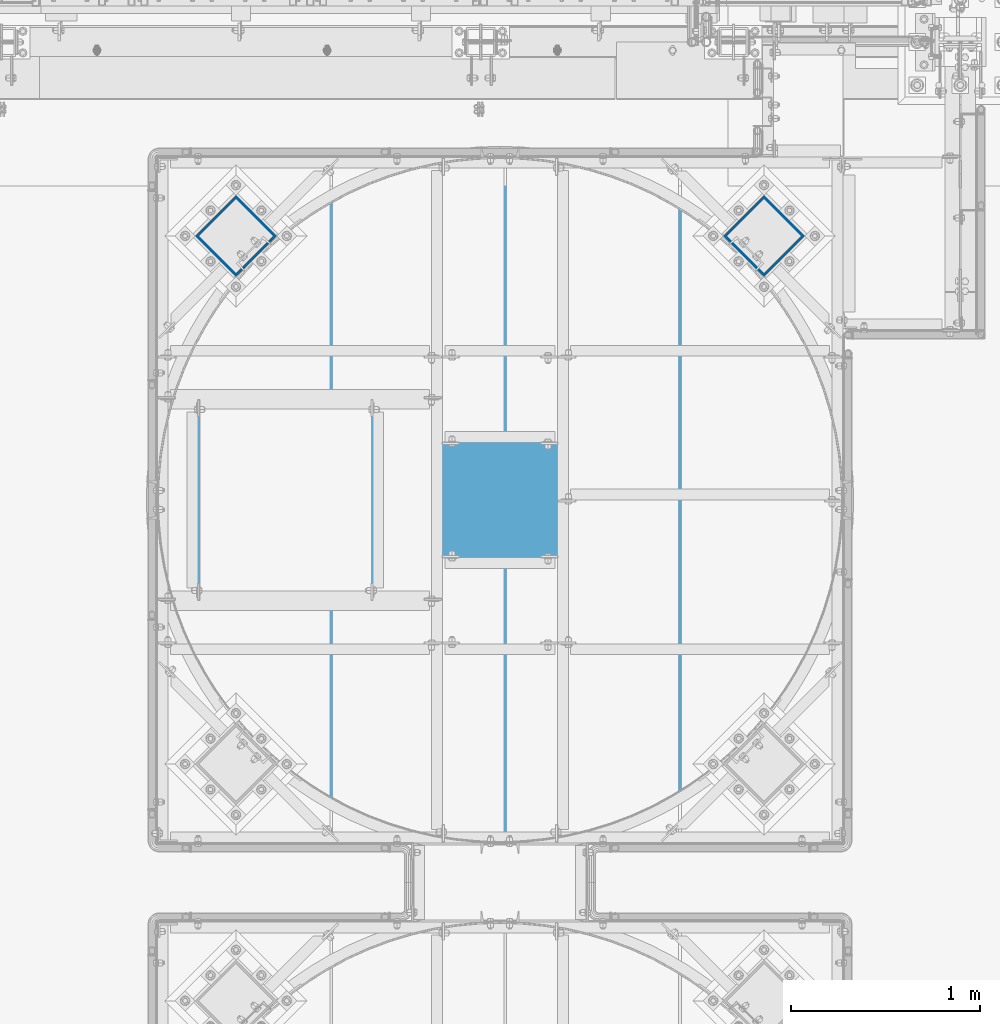
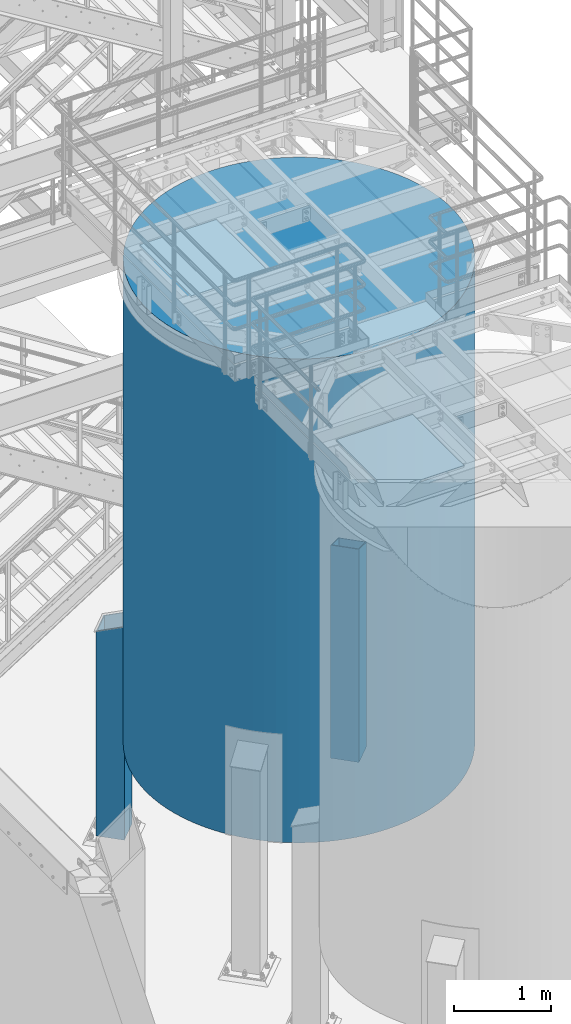
# One storey, part 577 of 1876: 3 columns, 3 elements without a shape of their own.
"""IFC2X3 building model written with IfcOpenShell, lengths in millimetres."""

from ifc_helpers import new_model, si_unit, frame, origin_with_axes, place, context, subcontext, project, spatial, faceted_brep, material, type_object, element, aggregate, save


model = new_model("IFC2X3")

# Units and contexts
model_context = context("Model", 3, precision=1e-05, world=origin_with_axes())
body_context = subcontext(model_context, "Body", "Model", "MODEL_VIEW")
ifc_project = project(units=[si_unit("LENGTHUNIT", "METRE", prefix="MILLI"), si_unit("AREAUNIT", "SQUARE_METRE"), si_unit("VOLUMEUNIT", "CUBIC_METRE"), si_unit("MASSUNIT", "GRAM", prefix="KILO"), si_unit("TIMEUNIT", "SECOND"), si_unit("PLANEANGLEUNIT", "RADIAN"), si_unit("SOLIDANGLEUNIT", "STERADIAN"), si_unit("THERMODYNAMICTEMPERATUREUNIT", "DEGREE_CELSIUS"), si_unit("LUMINOUSINTENSITYUNIT", "LUMEN")], contexts=[model_context])

# Site, building, storey
site_placement = place(None, origin_with_axes())
site = spatial("IfcSite", under=ifc_project, at=site_placement, CompositionType="ELEMENT")
building_placement = place(site_placement, origin_with_axes())
building = spatial("IfcBuilding", under=site, at=building_placement, Name="Undefined", CompositionType="ELEMENT")
storey_placement = place(building_placement, origin_with_axes())
storey = spatial("IfcBuildingStorey", under=building, at=storey_placement, Name="Undefined", CompositionType="ELEMENT", Elevation=0.0)

# Assembly, column
assembly_1_placement = place(storey_placement, origin_with_axes())
assembly_1 = element("IfcElementAssembly", 1, at=assembly_1_placement, inside=storey, Name="STORAGE TANK", AssemblyPlace="NOTDEFINED", PredefinedType="REINFORCEMENT_UNIT")
ifc_material_1 = material(Name="CONCRETE/3000")
column_type_1 = type_object("IfcColumnType", PredefinedType="NOTDEFINED")
column_1_placement = place(assembly_1_placement, frame((5181.60331443639, -9537.66435546875, 1524.0), z_axis=(-1.0, 0.0, 0.0), x_axis=(0.0, 0.0, 1.0)))
column_1 = element("IfcColumn", 2, at=column_1_placement, type_object=column_type_1, material=ifc_material_1, Name="STORAGE TANK", context=body_context, shape_type="Brep", body=[
    faceted_brep([(0.0, -1816.1, 0.0), (0.0, -1812.21159049363, -118.778622994864), (6096.0, -1812.21159049363, -118.778622994864), (6096.0, -1816.1, 0.0), (0.0, -1800.56301274098, -237.048617690837), (6096.0, -1800.56301274098, -237.048617690837), (0.0, -1781.20414774031, -354.303533813491), (6096.0, -1781.20414774031, -354.303533813491), (0.0, -1754.21789312358, -470.04126781069), (6096.0, -1754.21789312358, -470.04126781069), (0.0, -1719.71980817606, -583.766212937072), (6096.0, -1719.71980817606, -583.766212937072), (0.0, -1677.85761899375, -694.991381518241), (6096.0, -1677.85761899375, -694.991381518241), (0.0, -1628.81058589751, -803.24049030673), (6096.0, -1628.81058589751, -803.24049030673), (0.0, -1572.78873581292, -908.050000000001), (6096.0, -1572.78873581292, -908.050000000001), (0.0, -1510.03196290265, -1008.9711001869), (6096.0, -1510.03196290265, -1008.9711001869), (0.0, -1440.80900130291, -1105.57163122274), (6096.0, -1440.80900130291, -1105.57163122274), (0.0, -1365.41627436257, -1197.43793480324), (6096.0, -1365.41627436257, -1197.43793480324), (0.0, -1284.17662531289, -1284.17662531289), (6096.0, -1284.17662531289, -1284.17662531289), (0.0, -1197.43793480323, -1365.41627436257), (6096.0, -1197.43793480323, -1365.41627436257), (0.0, -1105.57163122274, -1440.80900130291), (6096.0, -1105.57163122274, -1440.80900130291), (0.0, -1008.9711001869, -1510.03196290265), (6096.0, -1008.9711001869, -1510.03196290265), (0.0, -908.049999999999, -1572.78873581292), (6096.0, -908.049999999999, -1572.78873581292), (0.0, -803.240490306727, -1628.81058589752), (6096.0, -803.240490306727, -1628.81058589752), (0.0, -694.991381518239, -1677.85761899375), (6096.0, -694.991381518239, -1677.85761899375), (0.0, -583.766212937071, -1719.71980817606), (6096.0, -583.766212937071, -1719.71980817606), (0.0, -470.041267810688, -1754.21789312358), (6096.0, -470.041267810688, -1754.21789312358), (0.0, -354.303533813489, -1781.20414774031), (6096.0, -354.303533813489, -1781.20414774031), (0.0, -237.048617690834, -1800.56301274098), (6096.0, -237.048617690834, -1800.56301274098), (0.0, -118.778622994862, -1812.21159049363), (6096.0, -118.778622994862, -1812.21159049363), (0.0, 0.0, -1816.1), (6096.0, 0.0, -1816.1), (0.0, 118.778622994863, -1812.21159049363), (6096.0, 118.778622994863, -1812.21159049363), (0.0, 237.048617690838, -1800.56301274098), (6096.0, 237.048617690838, -1800.56301274098), (0.0, 354.303533813491, -1781.20414774031), (6096.0, 354.303533813491, -1781.20414774031), (0.0, 470.04126781069, -1754.21789312358), (6096.0, 470.04126781069, -1754.21789312358), (0.0, 583.766212937073, -1719.71980817606), (6096.0, 583.766212937073, -1719.71980817606), (0.0, 694.991381518241, -1677.85761899375), (6096.0, 694.991381518241, -1677.85761899375), (0.0, 803.240490306729, -1628.81058589752), (6096.0, 803.240490306729, -1628.81058589752), (0.0, 908.050000000001, -1572.78873581292), (6096.0, 908.050000000001, -1572.78873581292), (0.0, 1008.9711001869, -1510.03196290265), (6096.0, 1008.9711001869, -1510.03196290265), (0.0, 1105.57163122274, -1440.80900130291), (6096.0, 1105.57163122274, -1440.80900130291), (0.0, 1197.43793480324, -1365.41627436257), (6096.0, 1197.43793480324, -1365.41627436257), (0.0, 1284.17662531289, -1284.17662531289), (6096.0, 1284.17662531289, -1284.17662531289), (0.0, 1365.41627436257, -1197.43793480323), (6096.0, 1365.41627436257, -1197.43793480323), (0.0, 1440.80900130291, -1105.57163122274), (6096.0, 1440.80900130291, -1105.57163122274), (0.0, 1510.03196290265, -1008.9711001869), (6096.0, 1510.03196290265, -1008.9711001869), (0.0, 1572.78873581292, -908.049999999999), (6096.0, 1572.78873581292, -908.049999999999), (0.0, 1628.81058589752, -803.240490306728), (6096.0, 1628.81058589752, -803.240490306728), (0.0, 1677.85761899375, -694.991381518238), (6096.0, 1677.85761899375, -694.991381518238), (0.0, 1719.71980817606, -583.766212937071), (6096.0, 1719.71980817606, -583.766212937071), (0.0, 1754.21789312358, -470.041267810687), (6096.0, 1754.21789312358, -470.041267810687), (0.0, 1781.20414774031, -354.30353381349), (6096.0, 1781.20414774031, -354.30353381349), (0.0, 1800.56301274098, -237.048617690835), (6096.0, 1800.56301274098, -237.048617690835), (0.0, 1812.21159049363, -118.778622994862), (6096.0, 1812.21159049363, -118.778622994862), (0.0, 1816.1, 0.0), (6096.0, 1816.1, 0.0), (0.0, 1812.21159049363, 118.778622994863), (6096.0, 1812.21159049363, 118.778622994863), (0.0, 1800.56301274098, 237.048617690836), (6096.0, 1800.56301274098, 237.048617690836), (0.0, 1781.20414774031, 354.303533813491), (6096.0, 1781.20414774031, 354.303533813491), (0.0, 1754.21789312358, 470.041267810689), (6096.0, 1754.21789312358, 470.041267810689), (0.0, 1719.71980817606, 583.766212937072), (6096.0, 1719.71980817606, 583.766212937072), (0.0, 1677.85761899375, 694.99138151824), (6096.0, 1677.85761899375, 694.99138151824), (0.0, 1628.81058589752, 803.240490306729), (6096.0, 1628.81058589752, 803.240490306729), (0.0, 1572.78873581292, 908.05), (6096.0, 1572.78873581292, 908.05), (0.0, 1510.03196290265, 1008.9711001869), (6096.0, 1510.03196290265, 1008.9711001869), (0.0, 1440.80900130291, 1105.57163122274), (6096.0, 1440.80900130291, 1105.57163122274), (0.0, 1365.41627436257, 1197.43793480324), (6096.0, 1365.41627436257, 1197.43793480324), (0.0, 1284.17662531289, 1284.17662531289), (6096.0, 1284.17662531289, 1284.17662531289), (0.0, 1197.43793480323, 1365.41627436257), (6096.0, 1197.43793480323, 1365.41627436257), (0.0, 1105.57163122274, 1440.80900130291), (6096.0, 1105.57163122274, 1440.80900130291), (0.0, 1008.9711001869, 1510.03196290265), (6096.0, 1008.9711001869, 1510.03196290265), (0.0, 908.049999999999, 1572.78873581292), (6096.0, 908.049999999999, 1572.78873581292), (0.0, 803.240490306727, 1628.81058589752), (6096.0, 803.240490306727, 1628.81058589752), (0.0, 694.991381518239, 1677.85761899375), (6096.0, 694.991381518239, 1677.85761899375), (0.0, 583.766212937071, 1719.71980817606), (6096.0, 583.766212937071, 1719.71980817606), (0.0, 470.041267810688, 1754.21789312358), (6096.0, 470.041267810688, 1754.21789312358), (0.0, 354.303533813491, 1781.20414774031), (6096.0, 354.303533813491, 1781.20414774031), (0.0, 237.048617690836, 1800.56301274098), (6096.0, 237.048617690836, 1800.56301274098), (0.0, 118.778622994863, 1812.21159049363), (6096.0, 118.778622994863, 1812.21159049363), (0.0, 0.0, 1816.1), (6096.0, 0.0, 1816.1), (0.0, -118.778622994863, 1812.21159049363), (6096.0, -118.778622994863, 1812.21159049363), (0.0, -237.048617690836, 1800.56301274098), (6096.0, -237.048617690836, 1800.56301274098), (0.0, -354.303533813491, 1781.20414774031), (6096.0, -354.303533813491, 1781.20414774031), (0.0, -470.041267810688, 1754.21789312358), (6096.0, -470.041267810688, 1754.21789312358), (0.0, -583.766212937071, 1719.71980817606), (6096.0, -583.766212937071, 1719.71980817606), (0.0, -694.991381518239, 1677.85761899375), (6096.0, -694.991381518239, 1677.85761899375), (0.0, -803.240490306729, 1628.81058589752), (6096.0, -803.240490306729, 1628.81058589752), (0.0, -908.050000000001, 1572.78873581292), (6096.0, -908.050000000001, 1572.78873581292), (0.0, -1008.9711001869, 1510.03196290265), (6096.0, -1008.9711001869, 1510.03196290265), (0.0, -1105.57163122274, 1440.80900130291), (6096.0, -1105.57163122274, 1440.80900130291), (0.0, -1197.43793480323, 1365.41627436257), (6096.0, -1197.43793480323, 1365.41627436257), (0.0, -1284.17662531289, 1284.17662531289), (6096.0, -1284.17662531289, 1284.17662531289), (0.0, -1365.41627436257, 1197.43793480324), (6096.0, -1365.41627436257, 1197.43793480324), (0.0, -1440.80900130291, 1105.57163122274), (6096.0, -1440.80900130291, 1105.57163122274), (0.0, -1510.03196290265, 1008.9711001869), (6096.0, -1510.03196290265, 1008.9711001869), (0.0, -1572.78873581292, 908.05), (6096.0, -1572.78873581292, 908.05), (0.0, -1628.81058589752, 803.240490306728), (6096.0, -1628.81058589752, 803.240490306728), (0.0, -1677.85761899375, 694.99138151824), (6096.0, -1677.85761899375, 694.99138151824), (0.0, -1719.71980817606, 583.766212937072), (6096.0, -1719.71980817606, 583.766212937072), (0.0, -1754.21789312358, 470.041267810688), (6096.0, -1754.21789312358, 470.041267810688), (0.0, -1781.20414774031, 354.303533813491), (6096.0, -1781.20414774031, 354.303533813491), (0.0, -1800.56301274098, 237.048617690835), (6096.0, -1800.56301274098, 237.048617690835), (0.0, -1812.21159049363, 118.778622994862), (6096.0, -1812.21159049363, 118.778622994862)], [[[0, 1, 2, 3]], [[1, 4, 5, 2]], [[4, 6, 7, 5]], [[6, 8, 9, 7]], [[8, 10, 11, 9]], [[10, 12, 13, 11]], [[12, 14, 15, 13]], [[14, 16, 17, 15]], [[16, 18, 19, 17]], [[18, 20, 21, 19]], [[20, 22, 23, 21]], [[22, 24, 25, 23]], [[24, 26, 27, 25]], [[26, 28, 29, 27]], [[28, 30, 31, 29]], [[30, 32, 33, 31]], [[32, 34, 35, 33]], [[34, 36, 37, 35]], [[36, 38, 39, 37]], [[38, 40, 41, 39]], [[40, 42, 43, 41]], [[42, 44, 45, 43]], [[44, 46, 47, 45]], [[46, 48, 49, 47]], [[48, 50, 51, 49]], [[50, 52, 53, 51]], [[52, 54, 55, 53]], [[54, 56, 57, 55]], [[56, 58, 59, 57]], [[58, 60, 61, 59]], [[60, 62, 63, 61]], [[62, 64, 65, 63]], [[64, 66, 67, 65]], [[66, 68, 69, 67]], [[68, 70, 71, 69]], [[70, 72, 73, 71]], [[72, 74, 75, 73]], [[74, 76, 77, 75]], [[76, 78, 79, 77]], [[78, 80, 81, 79]], [[80, 82, 83, 81]], [[82, 84, 85, 83]], [[84, 86, 87, 85]], [[86, 88, 89, 87]], [[88, 90, 91, 89]], [[90, 92, 93, 91]], [[92, 94, 95, 93]], [[94, 96, 97, 95]], [[96, 98, 99, 97]], [[98, 100, 101, 99]], [[100, 102, 103, 101]], [[102, 104, 105, 103]], [[104, 106, 107, 105]], [[106, 108, 109, 107]], [[108, 110, 111, 109]], [[110, 112, 113, 111]], [[112, 114, 115, 113]], [[114, 116, 117, 115]], [[116, 118, 119, 117]], [[118, 120, 121, 119]], [[120, 122, 123, 121]], [[122, 124, 125, 123]], [[124, 126, 127, 125]], [[126, 128, 129, 127]], [[128, 130, 131, 129]], [[130, 132, 133, 131]], [[132, 134, 135, 133]], [[134, 136, 137, 135]], [[136, 138, 139, 137]], [[138, 140, 141, 139]], [[140, 142, 143, 141]], [[142, 144, 145, 143]], [[144, 146, 147, 145]], [[146, 148, 149, 147]], [[148, 150, 151, 149]], [[150, 152, 153, 151]], [[152, 154, 155, 153]], [[154, 156, 157, 155]], [[156, 158, 159, 157]], [[158, 160, 161, 159]], [[160, 162, 163, 161]], [[162, 164, 165, 163]], [[164, 166, 167, 165]], [[166, 168, 169, 167]], [[168, 170, 171, 169]], [[170, 172, 173, 171]], [[172, 174, 175, 173]], [[174, 176, 177, 175]], [[176, 178, 179, 177]], [[178, 180, 181, 179]], [[180, 182, 183, 181]], [[182, 184, 185, 183]], [[184, 186, 187, 185]], [[186, 188, 189, 187]], [[188, 190, 191, 189]], [[190, 0, 3, 191]], [[5, 7, 9, 11, 13, 15, 17, 19, 21, 23, 25, 27, 29, 31, 33, 35, 37, 39, 41, 43, 45, 47, 49, 51, 53, 55, 57, 59, 61, 63, 65, 67, 69, 71, 73, 75, 77, 79, 81, 83, 85, 87, 89, 91, 93, 95, 97, 99, 101, 103, 105, 107, 109, 111, 113, 115, 117, 119, 121, 123, 125, 127, 129, 131, 133, 135, 137, 139, 141, 143, 145, 147, 149, 151, 153, 155, 157, 159, 161, 163, 165, 167, 169, 171, 173, 175, 177, 179, 181, 183, 185, 187, 189, 191, 3, 2]], [[190, 188, 186, 184, 182, 180, 178, 176, 174, 172, 170, 168, 166, 164, 162, 160, 158, 156, 154, 152, 150, 148, 146, 144, 142, 140, 138, 136, 134, 132, 130, 128, 126, 124, 122, 120, 118, 116, 114, 112, 110, 108, 106, 104, 102, 100, 98, 96, 94, 92, 90, 88, 86, 84, 82, 80, 78, 76, 74, 72, 70, 68, 66, 64, 62, 60, 58, 56, 54, 52, 50, 48, 46, 44, 42, 40, 38, 36, 34, 32, 30, 28, 26, 24, 22, 20, 18, 16, 14, 12, 10, 8, 6, 4, 1, 0]]]),
])
aggregate(assembly_1, [column_1])

assembly_2_placement = place(storey_placement, origin_with_axes())
assembly_2 = element("IfcElementAssembly", 3, at=assembly_2_placement, inside=storey, Name="COLUMN", AssemblyPlace="NOTDEFINED", PredefinedType="RIGID_FRAME")
ifc_material_2 = material()
column_type_2 = type_object("IfcColumnType", Name="HSS12X12X1/2", PredefinedType="NOTDEFINED")
column_2_placement = place(assembly_2_placement, frame((3783.01619380156, -8138.97037891887, 0.0), z_axis=(-0.707106781186547, -0.707106781186548, 0.0), x_axis=(0.0, 0.0, 1.0)))
column_2 = element("IfcColumn", 4, at=column_2_placement, type_object=column_type_2, material=ifc_material_2, Name="COLUMN", ObjectType="HSS12X12X1/2", context=body_context, shape_type="Brep", body=[
    faceted_brep([(57.15, 139.700000000023, -139.700000000023), (57.15, -139.700000000026, -139.700000000023), (2738.57757814383, -139.700000000026, -139.700000000022), (2636.8842951776, 139.700000000023, -139.700000000023), (57.15, -139.700000000026, 139.700000000026), (2738.57757814383, -139.700000000026, 139.700000000024), (57.15, 139.700000000021, 139.700000000025), (2636.8842951776, 139.700000000021, 139.700000000025), (57.15, 152.400000000023, -152.400000000025), (57.15, 152.400000000023, 152.400000000027), (2632.26187322459, 152.400000000023, 152.400000000028), (2632.26187322459, 152.400000000023, -152.400000000025), (57.15, -152.400000000031, 152.400000000027), (2743.20000009684, -152.400000000027, 152.400000000027), (57.15, -152.400000000027, -152.400000000024), (2743.20000009684, -152.400000000029, -152.400000000024)], [[[0, 1, 2, 3]], [[1, 4, 5, 2]], [[4, 6, 7, 5]], [[6, 0, 3, 7]], [[8, 9, 10, 11]], [[9, 12, 13, 10]], [[12, 14, 15, 13]], [[14, 8, 11, 15]], [[13, 15, 11, 10], [5, 7, 3, 2]], [[14, 12, 9, 8], [6, 4, 1, 0]]]),
])
aggregate(assembly_2, [column_2])

assembly_3_placement = place(storey_placement, origin_with_axes())
assembly_3 = element("IfcElementAssembly", 5, at=assembly_3_placement, inside=storey, Name="COLUMN", AssemblyPlace="NOTDEFINED", PredefinedType="RIGID_FRAME")
column_3_placement = place(assembly_3_placement, frame((6580.27820529291, -8139.02510914348, 0.0), z_axis=(-0.707106781186547, -0.707106781186548, 0.0), x_axis=(0.0, 0.0, 1.0)))
column_3 = element("IfcColumn", 6, at=column_3_placement, type_object=column_type_2, material=ifc_material_2, Name="COLUMN", ObjectType="HSS12X12X1/2", context=body_context, shape_type="Brep", body=[
    faceted_brep([(57.15, 139.700000000023, -139.700000000023), (57.15, -139.700000000026, -139.700000000023), (2636.88429517532, -139.700000000026, -139.700000000023), (2636.8842951776, 139.700000000023, -139.700000000023), (57.15, -139.700000000026, 139.700000000026), (2738.57757814383, -139.700000000026, 139.700000000024), (57.15, 139.700000000021, 139.700000000025), (2738.57757814155, 139.700000000021, 139.700000000025), (57.15, 152.400000000023, -152.400000000025), (57.15, 152.400000000023, 152.400000000027), (2743.20000009456, 152.400000000023, 152.400000000027), (2632.26187322459, 152.400000000023, -152.400000000025), (57.15, -152.400000000031, 152.400000000027), (2743.20000009684, -152.400000000027, 152.400000000027), (57.15, -152.400000000027, -152.400000000024), (2632.2618732223, -152.400000000027, -152.400000000024)], [[[0, 1, 2, 3]], [[1, 4, 5, 2]], [[4, 6, 7, 5]], [[6, 0, 3, 7]], [[8, 9, 10, 11]], [[9, 12, 13, 10]], [[12, 14, 15, 13]], [[14, 8, 11, 15]], [[13, 15, 11, 10], [5, 7, 3, 2]], [[14, 12, 9, 8], [6, 4, 1, 0]]]),
])
aggregate(assembly_3, [column_3])

save(model, "model.ifc")
